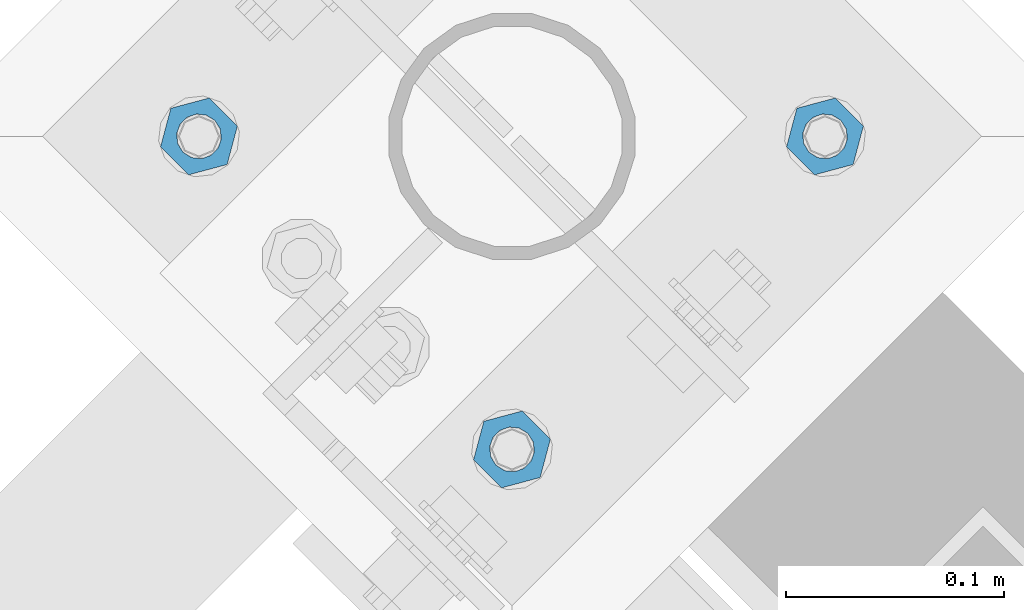
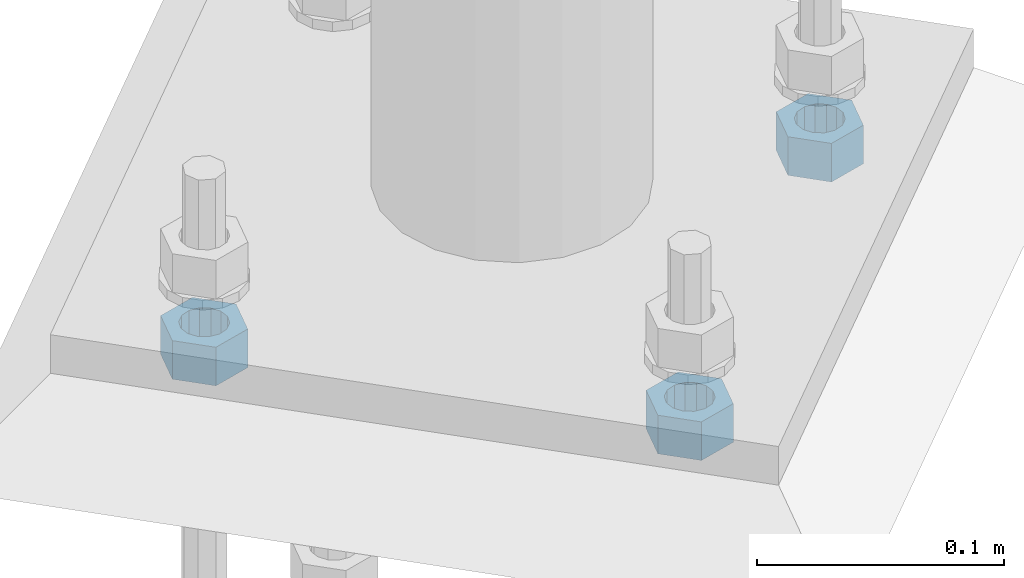
# One storey, part 630 of 975: 3 beams.
"""IFC2X3 building model written with IfcOpenShell, lengths in millimetres."""

from ifc_helpers import new_model, si_unit, frame, origin_with_axes, place, context, subcontext, project, spatial, faceted_brep, material, type_object, element, save


model = new_model("IFC2X3")

# Units and contexts
model_context = context("Model", 3, precision=1e-05, world=origin_with_axes())
body_context = subcontext(model_context, "Body", "Model", "MODEL_VIEW")
ifc_project = project(units=[si_unit("LENGTHUNIT", "METRE", prefix="MILLI"), si_unit("AREAUNIT", "SQUARE_METRE"), si_unit("VOLUMEUNIT", "CUBIC_METRE"), si_unit("MASSUNIT", "GRAM", prefix="KILO"), si_unit("TIMEUNIT", "SECOND"), si_unit("PLANEANGLEUNIT", "RADIAN"), si_unit("SOLIDANGLEUNIT", "STERADIAN"), si_unit("THERMODYNAMICTEMPERATUREUNIT", "DEGREE_CELSIUS"), si_unit("LUMINOUSINTENSITYUNIT", "LUMEN")], contexts=[model_context])

# Site, building, storey
site_placement = place(None, origin_with_axes())
site = spatial("IfcSite", under=ifc_project, at=site_placement, CompositionType="ELEMENT")
building_placement = place(site_placement, origin_with_axes())
building = spatial("IfcBuilding", under=site, at=building_placement, Name="Undefined", CompositionType="ELEMENT")
storey_placement = place(building_placement, origin_with_axes())
storey = spatial("IfcBuildingStorey", under=building, at=storey_placement, Name="Undefined", CompositionType="ELEMENT", Elevation=0.0)

# Beams
ifc_material = material(Name="STEEL/A36")
beam_type = type_object("IfcBeamType", Name="3/4_HEAVY_HEX_NUT", PredefinedType="NOTDEFINED")
beam_1_placement = place(storey_placement, frame((26412.0159053001, 22078.950001079, -266.7), z_axis=(-0.707106781186548, -0.707106781186548, 0.0), x_axis=(0.0, 0.0, -1.0)))
element("IfcBeam", 1, at=beam_1_placement, inside=storey, type_object=beam_type, material=ifc_material, Name="NUT", ObjectType="3/4_HEAVY_HEX_NUT", context=body_context, shape_type="Brep", body=[
    faceted_brep([(0.0, -18.2600002288818, 0.0), (0.0, -9.13000011444092, -15.8100004196167), (19.0499999999993, -9.13000011444092, -15.8100004196167), (19.0499999999993, -18.2600002288818, 0.0), (0.0, 9.13000011444092, -15.8100004196167), (19.0499999999993, 9.13000011444092, -15.8100004196167), (0.0, 18.2600002288818, 0.0), (19.0499999999993, 18.2600002288818, 0.0), (0.0, 9.13000011444092, 15.8100004196167), (19.0499999999993, 9.13000011444092, 15.8100004196167), (0.0, -9.13000011444092, 15.8100004196167), (19.0499999999993, -9.13000011444092, 15.8100004196167), (0.0, 0.0, 10.3199996948242), (0.0, 4.47768005528269, 9.29799844179911), (19.0499999999993, 4.47768005528269, 9.29799844179911), (19.0499999999993, 0.0, 10.3199996948242), (0.0, 8.06850066047446, 6.43441456490817), (19.0499999999993, 8.06850066047446, 6.43441456490817), (0.0, 10.0612557561917, 2.29641597052117), (19.0499999999993, 10.0612557561917, 2.29641597052117), (0.0, 10.0612557561917, -2.29641597052117), (19.0499999999993, 10.0612557561917, -2.29641597052117), (0.0, 8.06850066047446, -6.43441456490814), (19.0499999999993, 8.06850066047446, -6.43441456490814), (0.0, 4.47768005528269, -9.29799844179908), (19.0499999999993, 4.47768005528269, -9.29799844179908), (0.0, 0.0, -10.3199996948242), (19.0499999999993, 0.0, -10.3199996948242), (0.0, -4.47768005528269, -9.29799844179911), (19.0499999999993, -4.47768005528269, -9.29799844179911), (0.0, -8.06850066047446, -6.43441456490817), (19.0499999999993, -8.06850066047446, -6.43441456490817), (0.0, -10.0612557561917, -2.29641597052117), (19.0499999999993, -10.0612557561917, -2.29641597052117), (0.0, -10.0612557561917, 2.29641597052117), (19.0499999999993, -10.0612557561917, 2.29641597052117), (0.0, -8.06850066047446, 6.43441456490814), (19.0499999999993, -8.06850066047446, 6.43441456490814), (0.0, -4.47768005528269, 9.29799844179908), (19.0499999999993, -4.47768005528269, 9.29799844179908)], [[[0, 1, 2, 3]], [[1, 4, 5, 2]], [[4, 6, 7, 5]], [[6, 8, 9, 7]], [[8, 10, 11, 9]], [[10, 0, 3, 11]], [[12, 13, 14, 15]], [[13, 16, 17, 14]], [[16, 18, 19, 17]], [[18, 20, 21, 19]], [[20, 22, 23, 21]], [[22, 24, 25, 23]], [[24, 26, 27, 25]], [[26, 28, 29, 27]], [[28, 30, 31, 29]], [[30, 32, 33, 31]], [[32, 34, 35, 33]], [[34, 36, 37, 35]], [[36, 38, 39, 37]], [[38, 12, 15, 39]], [[5, 7, 9, 11, 3, 2], [17, 19, 21, 23, 25, 27, 29, 31, 33, 35, 37, 39, 15, 14]], [[10, 8, 6, 4, 1, 0], [38, 36, 34, 32, 30, 28, 26, 24, 22, 20, 18, 16, 13, 12]]]),
])
beam_2_placement = place(storey_placement, frame((26555.700001079, 21935.2659053001, -266.7), z_axis=(0.707106781186548, 0.707106781186548, 0.0), x_axis=(0.0, 0.0, -1.0)))
element("IfcBeam", 2, at=beam_2_placement, inside=storey, type_object=beam_type, material=ifc_material, Name="NUT", ObjectType="3/4_HEAVY_HEX_NUT", context=body_context, shape_type="Brep", body=[
    faceted_brep([(0.0, -18.2600002288818, 0.0), (0.0, -9.13000011444092, -15.8100004196167), (19.0499999999993, -9.13000011444092, -15.8100004196167), (19.0499999999993, -18.2600002288818, 0.0), (0.0, 9.13000011444092, -15.8100004196167), (19.0499999999993, 9.13000011444092, -15.8100004196167), (0.0, 18.2600002288818, 0.0), (19.0499999999993, 18.2600002288818, 0.0), (0.0, 9.13000011444092, 15.8100004196167), (19.0499999999993, 9.13000011444092, 15.8100004196167), (0.0, -9.13000011444092, 15.8100004196167), (19.0499999999993, -9.13000011444092, 15.8100004196167), (0.0, 0.0, 10.3199996948242), (0.0, 4.47768005528269, 9.29799844179911), (19.0499999999993, 4.47768005528269, 9.29799844179911), (19.0499999999993, 0.0, 10.3199996948242), (0.0, 8.06850066047446, 6.43441456490817), (19.0499999999993, 8.06850066047446, 6.43441456490817), (0.0, 10.0612557561917, 2.29641597052117), (19.0499999999993, 10.0612557561917, 2.29641597052117), (0.0, 10.0612557561917, -2.29641597052117), (19.0499999999993, 10.0612557561917, -2.29641597052117), (0.0, 8.06850066047446, -6.43441456490814), (19.0499999999993, 8.06850066047446, -6.43441456490814), (0.0, 4.47768005528269, -9.29799844179908), (19.0499999999993, 4.47768005528269, -9.29799844179908), (0.0, 0.0, -10.3199996948242), (19.0499999999993, 0.0, -10.3199996948242), (0.0, -4.47768005528269, -9.29799844179911), (19.0499999999993, -4.47768005528269, -9.29799844179911), (0.0, -8.06850066047446, -6.43441456490817), (19.0499999999993, -8.06850066047446, -6.43441456490817), (0.0, -10.0612557561917, -2.29641597052117), (19.0499999999993, -10.0612557561917, -2.29641597052117), (0.0, -10.0612557561917, 2.29641597052117), (19.0499999999993, -10.0612557561917, 2.29641597052117), (0.0, -8.06850066047446, 6.43441456490814), (19.0499999999993, -8.06850066047446, 6.43441456490814), (0.0, -4.47768005528269, 9.29799844179908), (19.0499999999993, -4.47768005528269, 9.29799844179908)], [[[0, 1, 2, 3]], [[1, 4, 5, 2]], [[4, 6, 7, 5]], [[6, 8, 9, 7]], [[8, 10, 11, 9]], [[10, 0, 3, 11]], [[12, 13, 14, 15]], [[13, 16, 17, 14]], [[16, 18, 19, 17]], [[18, 20, 21, 19]], [[20, 22, 23, 21]], [[22, 24, 25, 23]], [[24, 26, 27, 25]], [[26, 28, 29, 27]], [[28, 30, 31, 29]], [[30, 32, 33, 31]], [[32, 34, 35, 33]], [[34, 36, 37, 35]], [[36, 38, 39, 37]], [[38, 12, 15, 39]], [[5, 7, 9, 11, 3, 2], [17, 19, 21, 23, 25, 27, 29, 31, 33, 35, 37, 39, 15, 14]], [[10, 8, 6, 4, 1, 0], [38, 36, 34, 32, 30, 28, 26, 24, 22, 20, 18, 16, 13, 12]]]),
])
beam_3_placement = place(storey_placement, frame((26699.3840968578, 22078.950001079, -266.7), z_axis=(0.707106781186548, 0.707106781186548, 0.0), x_axis=(0.0, 0.0, -1.0)))
element("IfcBeam", 3, at=beam_3_placement, inside=storey, type_object=beam_type, material=ifc_material, Name="NUT", ObjectType="3/4_HEAVY_HEX_NUT", context=body_context, shape_type="Brep", body=[
    faceted_brep([(0.0, -18.2600002288818, 0.0), (0.0, -9.13000011444092, -15.8100004196167), (19.0499999999993, -9.13000011444092, -15.8100004196167), (19.0499999999993, -18.2600002288818, 0.0), (0.0, 9.13000011444092, -15.8100004196167), (19.0499999999993, 9.13000011444092, -15.8100004196167), (0.0, 18.2600002288818, 0.0), (19.0499999999993, 18.2600002288818, 0.0), (0.0, 9.13000011444092, 15.8100004196167), (19.0499999999993, 9.13000011444092, 15.8100004196167), (0.0, -9.13000011444092, 15.8100004196167), (19.0499999999993, -9.13000011444092, 15.8100004196167), (0.0, 0.0, 10.3199996948242), (0.0, 4.47768005528269, 9.29799844179911), (19.0499999999993, 4.47768005528269, 9.29799844179911), (19.0499999999993, 0.0, 10.3199996948242), (0.0, 8.06850066047446, 6.43441456490817), (19.0499999999993, 8.06850066047446, 6.43441456490817), (0.0, 10.0612557561917, 2.29641597052117), (19.0499999999993, 10.0612557561917, 2.29641597052117), (0.0, 10.0612557561917, -2.29641597052117), (19.0499999999993, 10.0612557561917, -2.29641597052117), (0.0, 8.06850066047446, -6.43441456490814), (19.0499999999993, 8.06850066047446, -6.43441456490814), (0.0, 4.47768005528269, -9.29799844179908), (19.0499999999993, 4.47768005528269, -9.29799844179908), (0.0, 0.0, -10.3199996948242), (19.0499999999993, 0.0, -10.3199996948242), (0.0, -4.47768005528269, -9.29799844179911), (19.0499999999993, -4.47768005528269, -9.29799844179911), (0.0, -8.06850066047446, -6.43441456490817), (19.0499999999993, -8.06850066047446, -6.43441456490817), (0.0, -10.0612557561917, -2.29641597052117), (19.0499999999993, -10.0612557561917, -2.29641597052117), (0.0, -10.0612557561917, 2.29641597052117), (19.0499999999993, -10.0612557561917, 2.29641597052117), (0.0, -8.06850066047446, 6.43441456490814), (19.0499999999993, -8.06850066047446, 6.43441456490814), (0.0, -4.47768005528269, 9.29799844179908), (19.0499999999993, -4.47768005528269, 9.29799844179908)], [[[0, 1, 2, 3]], [[1, 4, 5, 2]], [[4, 6, 7, 5]], [[6, 8, 9, 7]], [[8, 10, 11, 9]], [[10, 0, 3, 11]], [[12, 13, 14, 15]], [[13, 16, 17, 14]], [[16, 18, 19, 17]], [[18, 20, 21, 19]], [[20, 22, 23, 21]], [[22, 24, 25, 23]], [[24, 26, 27, 25]], [[26, 28, 29, 27]], [[28, 30, 31, 29]], [[30, 32, 33, 31]], [[32, 34, 35, 33]], [[34, 36, 37, 35]], [[36, 38, 39, 37]], [[38, 12, 15, 39]], [[5, 7, 9, 11, 3, 2], [17, 19, 21, 23, 25, 27, 29, 31, 33, 35, 37, 39, 15, 14]], [[10, 8, 6, 4, 1, 0], [38, 36, 34, 32, 30, 28, 26, 24, 22, 20, 18, 16, 13, 12]]]),
])

save(model, "model.ifc")
